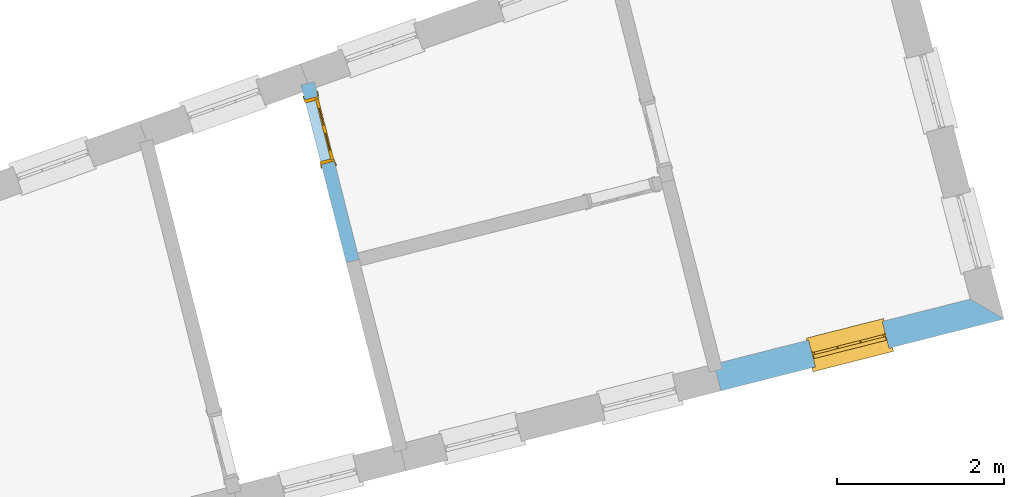
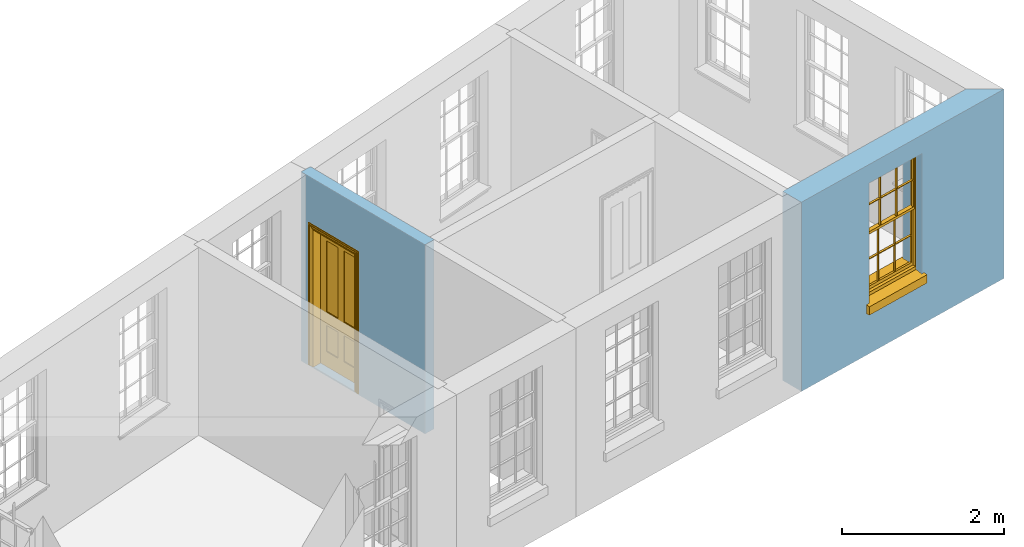
# One storey, part 6 of 11: 1 door, 1 window, 2 openings, plus 2 elements that do not belong to this part.
"""IFC2X3 building model written with IfcOpenShell, lengths in metres."""

from ifc_helpers import new_model, si_unit, frame, origin, place, context, subcontext, project, spatial, polyline, outline, extrude, faceted_brep, material, layer, layer_set, layer_usage, element, fill, save


model = new_model("IFC2X3")

# Units and contexts
model_context = context("Model", 3, world=origin())
body_context = subcontext(model_context, "Body", "Model", "MODEL_VIEW")
ifc_project = project(units=[si_unit("PLANEANGLEUNIT", "RADIAN"), si_unit("MASSUNIT", "GRAM", prefix="KILO"), si_unit("FORCEUNIT", "NEWTON", prefix="KILO"), si_unit("LENGTHUNIT", "METRE")], contexts=[model_context])

# Site, building, storey
site_placement = place(None, origin())
site = spatial("IfcSite", under=ifc_project, at=site_placement, CompositionType="ELEMENT")
building_placement = place(None, origin())
building = spatial("IfcBuilding", under=site, at=building_placement, Name="Building plot-13", CompositionType="ELEMENT")
storey_placement = place(None, frame((0.0, 0.0, 6.7)))
storey = spatial("IfcBuildingStorey", under=building, at=storey_placement, Name="Floor 1", CompositionType="ELEMENT", Elevation=6.7)

# Wall, opening, window
ifc_material_1 = material(Name="Masonry")
ifc_layer_1 = layer(ifc_material_1, 0.33, ventilated=False)
ifc_layer_set_1 = layer_set([ifc_layer_1], Name="My Wall")
ifc_layer_usage_1 = layer_usage(ifc_layer_set_1, "AXIS2", "NEGATIVE", 0.08)
wall_1_placement = place(storey_placement, origin())
wall_1 = element("IfcWallStandardCase", 1, at=wall_1_placement, inside=storey, material=ifc_layer_usage_1, Name="exterior", context=body_context, shape_type="SweptSolid", body=[
    extrude(outline(polyline([(76.9221166060511, 46.4727132498904), (77.0032448604169, 46.1528410780099), (80.3857854678444, 47.0107450750622), (79.9817754258731, 47.2487256724398), (76.9221166060511, 46.4727132498904)])), origin(), (0.0, 0.0, 1.0), 2.85),
])
opening_1_placement = place(storey_placement, frame((0.0, 0.0, 0.75)))
opening_1 = element("IfcOpeningElement", 2, at=opening_1_placement, cuts=wall_1, Name="Opening", ObjectType="Opening", context=body_context, shape_type="SweptSolid", body=[
    extrude(outline(polyline([(78.1311755833539, 46.4389148869927), (79.0132473300547, 46.6626321944863), (78.9321190756889, 46.9825043663668), (78.0500473289881, 46.7587870588732), (78.1311755833539, 46.4389148869927)])), origin(), (0.0, 0.0, 1.0), 1.82),
])
window_placement = place(storey_placement, frame((78.069714784592, 46.6812422899325, 0.75), z_axis=(0.0, 0.0, 1.0), x_axis=(0.882071746700802, 0.223717307493615, 0.0)))
window = element("IfcWindow", 3, at=window_placement, inside=storey, Name="bedroom outside window", OverallHeight=1.82, OverallWidth=0.91, context=body_context, shape_type="Brep", held_by="IfcProductRepresentation", body=[
    faceted_brep([(0.033125, -0.105, 0.975209), (0.01, -0.105, 0.975209), (0.033125, -0.105, 1.376042), (0.876875, -0.105, 0.975209), (0.876875, -0.105, 1.376042), (0.9, -0.105, 0.975209), (0.876875, -0.105, 1.386042), (0.876875, -0.105, 1.786875), (0.9, -0.105, 1.81), (0.033125, -0.105, 1.786875), (0.033125, -0.105, 1.386042), (0.01, -0.105, 1.81), (0.876875, -0.135, 1.376042), (0.876875, -0.135, 0.975209), (0.9, -0.135, 0.937083), (0.033125, -0.135, 1.786875), (0.01, -0.135, 1.81), (0.033125, -0.135, 1.386042), (0.01, -0.135, 0.937083), (0.033125, -0.135, 0.975209), (0.033125, -0.135, 1.376042), (0.876875, -0.135, 1.786875), (0.876875, -0.135, 1.386042), (0.9, -0.135, 1.81), (0.033125, -0.105, 0.937083), (0.01, -0.105, 0.937083), (0.033125, -0.105, 0.53625), (0.876875, -0.105, 0.937083), (0.876875, -0.105, 0.53625), (0.9, -0.105, 0.937083), (0.876875, -0.105, 0.52625), (0.876875, -0.105, 0.125417), (0.9, -0.105, 0.077167), (0.033125, -0.105, 0.125417), (0.033125, -0.105, 0.52625), (0.01, -0.105, 0.077167), (-0.0425, -0.25, 0.01), (-0.0425, -0.3, 0.001667), (0.0, -0.25, 0.01), (0.9525, -0.25, 0.01), (0.91, -0.25, 0.01), (0.9525, -0.3, 0.001667), (-0.02, 0.08, 0.077167), (0.0, 0.08, 0.077167), (-0.02, 0.11, 0.077167), (0.0, -0.06, 0.077167), (0.01, -0.06, 0.077167), (0.91, -0.06, 0.077167), (0.91, 0.08, 0.077167), (0.9, -0.06, 0.077167), (0.93, 0.08, 0.077167), (0.93, 0.11, 0.077167), (0.01, -0.075, 0.975209), (0.9, -0.075, 0.975209), (0.876875, -0.075, 0.125417), (0.876875, -0.075, 0.52625), (0.9, -0.075, 0.077167), (0.876875, -0.075, 0.53625), (0.876875, -0.075, 0.937083), (0.033125, -0.075, 0.125417), (0.01, -0.075, 0.077167), (0.033125, -0.075, 0.52625), (0.033125, -0.075, 0.937083), (0.033125, -0.075, 0.53625), (-0.02, 0.08, 0.052167), (-0.02, 0.11, 0.052167), (0.93, 0.11, 0.052167), (0.93, 0.08, 0.052167), (0.91, 0.08, 0.052167), (0.0, 0.08, 0.052167), (0.91, -0.15, 0.026667), (0.0, -0.15, 0.026667), (-0.0425, -0.3, -0.123333), (0.9525, -0.3, -0.123333), (-0.0425, -0.25, -0.123333), (0.9525, -0.25, -0.123333), (0.01, -0.06, 1.81), (0.9, -0.06, 1.81), (0.0, -0.06, 1.82), (0.91, -0.06, 1.82), (0.01, -0.15, 0.077167), (0.9, -0.15, 0.077167), (0.592292, -0.105, 0.125417), (0.592292, -0.075, 0.125417), (0.317708, -0.075, 0.125417), (0.317708, -0.105, 0.125417), (0.592292, -0.105, 0.53625), (0.317708, -0.105, 0.53625), (0.317708, -0.105, 0.52625), (0.592292, -0.105, 0.52625), (0.592292, -0.075, 0.53625), (0.317708, -0.075, 0.53625), (0.592292, -0.135, 1.386042), (0.592292, -0.105, 1.386042), (0.317708, -0.105, 1.386042), (0.317708, -0.135, 1.386042), (0.317708, -0.135, 1.376042), (0.592292, -0.135, 1.376042), (0.317708, -0.105, 1.376042), (0.592292, -0.105, 1.376042), (0.602292, -0.135, 1.376042), (0.592292, -0.135, 0.975209), (0.602292, -0.135, 0.975209), (0.602292, -0.105, 0.975209), (0.592292, -0.105, 0.975209), (0.602292, -0.105, 1.376042), (0.602292, -0.075, 0.53625), (0.602292, -0.105, 0.53625), (0.317708, -0.075, 0.52625), (0.307708, -0.075, 0.125417), (0.307708, -0.075, 0.52625), (0.602292, -0.075, 0.52625), (0.602292, -0.075, 0.125417), (0.592292, -0.075, 0.52625), (0.307708, -0.075, 0.53625), (0.317708, -0.075, 0.937083), (0.307708, -0.075, 0.937083), (0.602292, -0.075, 0.937083), (0.592292, -0.075, 0.937083), (0.307708, -0.105, 0.52625), (0.307708, -0.105, 0.125417), (0.307708, -0.105, 0.53625), (0.307708, -0.105, 0.937083), (0.592292, -0.105, 0.937083), (0.317708, -0.105, 0.937083), (0.602292, -0.105, 0.937083), (0.602292, -0.105, 0.52625), (0.602292, -0.105, 0.125417), (0.307708, -0.135, 1.386042), (0.307708, -0.135, 1.376042), (0.307708, -0.135, 0.975209), (0.317708, -0.135, 0.975209), (0.317708, -0.135, 1.786875), (0.307708, -0.135, 1.786875), (0.602292, -0.135, 1.786875), (0.592292, -0.135, 1.786875), (0.602292, -0.135, 1.386042), (0.602292, -0.105, 1.386042), (0.307708, -0.105, 1.386042), (0.307708, -0.105, 1.786875), (0.317708, -0.105, 1.786875), (0.592292, -0.105, 1.786875), (0.602292, -0.105, 1.786875), (0.307708, -0.105, 1.376042), (0.317708, -0.105, 0.975209), (0.307708, -0.105, 0.975209), (0.91, -0.15, 1.82), (0.9, -0.15, 1.81), (0.01, -0.15, 1.81), (0.0, -0.15, 1.82), (0.91, -0.25, 0.0), (0.0, -0.25, 0.0), (0.91, 0.08, 0.0), (0.0, 0.08, 0.0)], [[[0, 1, 2]], [[3, 4, 5]], [[6, 7, 8]], [[9, 10, 11]], [[12, 13, 14]], [[15, 16, 17]], [[18, 19, 20]], [[21, 22, 23]], [[24, 25, 26]], [[27, 28, 29]], [[30, 31, 32]], [[33, 34, 35]], [[14, 27, 29]], [[25, 24, 18]], [[36, 37, 38]], [[39, 40, 41]], [[42, 43, 44]], [[45, 46, 43]], [[47, 48, 49]], [[50, 51, 48]], [[1, 0, 52]], [[5, 53, 3]], [[54, 55, 56]], [[57, 58, 53]], [[59, 60, 61]], [[62, 63, 52]], [[48, 43, 46, 49]], [[51, 44, 43, 48]], [[64, 42, 44, 65]], [[65, 44, 51, 66]], [[66, 51, 50, 67]], [[65, 66, 68, 69]], [[60, 56, 49, 46]], [[70, 71, 38, 40]], [[37, 41, 40, 38]], [[37, 72, 73, 41]], [[74, 75, 73, 72]], [[8, 11, 76, 77]], [[76, 78, 79, 77]], [[32, 35, 80, 81]], [[81, 80, 71, 70]], [[82, 83, 84, 85]], [[86, 87, 88, 89]], [[86, 90, 91, 87]], [[92, 93, 94, 95]], [[92, 95, 96, 97]], [[96, 98, 99, 97]], [[100, 97, 101, 102]], [[103, 104, 99, 105]], [[97, 99, 104, 101]], [[102, 103, 105, 100]], [[28, 57, 106, 107]], [[108, 84, 109, 110]], [[111, 112, 83, 113]], [[114, 110, 61, 63]], [[90, 113, 108, 91]], [[115, 91, 114, 116]], [[117, 106, 90, 118]], [[111, 106, 57, 55]], [[119, 110, 109, 120]], [[34, 61, 110, 119]], [[89, 113, 83, 82]], [[88, 108, 113, 89]], [[85, 84, 108, 88]], [[121, 114, 63, 26]], [[122, 116, 114, 121]], [[123, 118, 90, 86]], [[87, 91, 115, 124]], [[107, 106, 117, 125]], [[126, 111, 55, 30]], [[127, 112, 111, 126]], [[126, 30, 28, 107]], [[88, 119, 120, 85]], [[126, 89, 82, 127]], [[125, 123, 86, 107]], [[121, 26, 34, 119]], [[124, 122, 121, 87]], [[128, 17, 20, 129]], [[96, 129, 130, 131]], [[132, 133, 128, 95]], [[134, 135, 92, 136]], [[100, 12, 22, 136]], [[137, 6, 4, 105]], [[94, 138, 139, 140]], [[137, 93, 141, 142]], [[99, 98, 94, 93]], [[143, 2, 10, 138]], [[144, 145, 143, 98]], [[129, 143, 145, 130]], [[20, 2, 143, 129]], [[131, 144, 98, 96]], [[128, 138, 10, 17]], [[133, 139, 138, 128]], [[135, 141, 93, 92]], [[95, 94, 140, 132]], [[22, 6, 137, 136]], [[136, 137, 142, 134]], [[100, 105, 4, 12]], [[107, 86, 89, 126]], [[106, 111, 113, 90]], [[91, 108, 110, 114]], [[87, 121, 119, 88]], [[97, 100, 136, 92]], [[129, 96, 95, 128]], [[98, 143, 138, 94]], [[105, 99, 93, 137]], [[131, 101, 104, 144]], [[124, 115, 118, 123]], [[132, 140, 141, 135]], [[120, 109, 59, 33]], [[15, 9, 139, 133]], [[134, 142, 7, 21]], [[31, 54, 112, 127]], [[36, 74, 72, 37]], [[39, 41, 73, 75]], [[18, 14, 101, 131]], [[23, 16, 132, 135]], [[83, 56, 60, 84]], [[52, 53, 118, 115]], [[53, 52, 144, 104]], [[11, 8, 141, 140]], [[14, 18, 124, 123]], [[2, 1, 11, 10]], [[8, 5, 4, 6]], [[57, 53, 56, 55]], [[60, 52, 63, 61]], [[26, 25, 35, 34]], [[32, 29, 28, 30]], [[14, 23, 22, 12]], [[18, 20, 17, 16]], [[19, 0, 2, 20]], [[17, 10, 9, 15]], [[12, 4, 3, 13]], [[21, 7, 6, 22]], [[27, 58, 57, 28]], [[30, 55, 54, 31]], [[33, 59, 61, 34]], [[26, 63, 62, 24]], [[5, 8, 77, 53]], [[76, 11, 1, 52]], [[46, 45, 78, 76]], [[49, 77, 79, 47]], [[70, 146, 147, 81]], [[71, 80, 148, 149]], [[19, 130, 145, 0]], [[102, 13, 3, 103]], [[116, 122, 24, 62]], [[29, 32, 81, 14]], [[80, 35, 25, 18]], [[60, 46, 76, 52]], [[77, 49, 56, 53]], [[23, 14, 81, 147]], [[16, 148, 80, 18]], [[35, 85, 120]], [[120, 33, 35]], [[127, 82, 32]], [[32, 31, 127]], [[32, 82, 85, 35]], [[102, 101, 14]], [[14, 13, 102]], [[18, 131, 130]], [[130, 19, 18]], [[134, 21, 23]], [[23, 135, 134]], [[16, 15, 133]], [[133, 132, 16]], [[11, 140, 139]], [[139, 9, 11]], [[142, 141, 8]], [[8, 7, 142]], [[23, 147, 148, 16]], [[146, 149, 148, 147]], [[52, 115, 116]], [[116, 62, 52]], [[118, 53, 117]], [[58, 117, 53]], [[27, 125, 117, 58]], [[56, 83, 112]], [[112, 54, 56]], [[109, 84, 60]], [[60, 59, 109]], [[125, 27, 14]], [[14, 123, 125]], [[122, 124, 18]], [[18, 24, 122]], [[145, 144, 52]], [[52, 0, 145]], [[103, 3, 53]], [[53, 104, 103]], [[79, 78, 149, 146]], [[78, 45, 71, 149]], [[146, 70, 47, 79]], [[150, 75, 74, 151]], [[68, 66, 67]], [[48, 68, 67, 50]], [[69, 64, 65]], [[42, 64, 69, 43]], [[69, 68, 152, 153]], [[70, 68, 48, 47]], [[150, 152, 68, 70]], [[43, 69, 71, 45]], [[69, 153, 151, 71]], [[152, 150, 151, 153]], [[38, 151, 74, 36]], [[71, 151, 38]], [[39, 75, 150, 40]], [[40, 150, 70]]]),
])
fill(opening_1, window)

# Wall, opening, door
ifc_material_2 = material(Name="Masonry")
ifc_layer_2 = layer(ifc_material_2, 0.16, ventilated=False)
ifc_layer_set_2 = layer_set([ifc_layer_2], Name="My Wall")
ifc_layer_usage_2 = layer_usage(ifc_layer_set_2, "AXIS2", "NEGATIVE", 0.08)
wall_2_placement = place(storey_placement, origin())
wall_2 = element("IfcWallStandardCase", 4, at=wall_2_placement, inside=storey, material=ifc_layer_usage_2, Name="interior", context=body_context, shape_type="SweptSolid", body=[
    extrude(outline(polyline([(72.1409472860622, 49.8463171225142), (71.9858577481808, 49.8069822113066), (72.5242252597805, 47.684308839971), (72.6793147976619, 47.7236437511786), (72.1409472860622, 49.8463171225142)])), origin(), (0.0, 0.0, 1.0), 2.85),
])
opening_2_placement = place(storey_placement, frame((0.0, 0.0, 0.0199999999999996)))
opening_2 = element("IfcOpeningElement", 5, at=opening_2_placement, cuts=wall_2, Name="Opening", ObjectType="Opening", context=body_context, shape_type="SweptSolid", body=[
    extrude(outline(polyline([(72.0301095232894, 49.6325064811899), (72.2267840793278, 48.8570587917826), (72.3818736172093, 48.8963937029903), (72.1851990611709, 49.6718413923976), (72.0301095232894, 49.6325064811899)])), origin(), (0.0, 0.0, 1.0), 2.1),
])
door_placement = place(storey_placement, frame((72.1076542922301, 49.6521739367938, 0.0199999999999996), z_axis=(0.0, 0.0, 1.0), x_axis=(0.196674556038388, -0.775447689407287, 0.0)))
door = element("IfcDoor", 6, at=door_placement, inside=storey, Name="circulation inside door", OverallHeight=2.1, OverallWidth=0.8, context=body_context, shape_type="Brep", held_by="IfcProductRepresentation", body=[
    faceted_brep([(0.773, 0.08, 1.895), (0.66, 0.08, 1.895), (0.66, 0.08, 2.073), (0.773, 0.08, 2.073), (0.773, 0.08, 0.82), (0.66, 0.08, 0.82), (0.45, 0.08, 1.895), (0.45, 0.08, 2.073), (0.773, 0.08, 0.62), (0.66, 0.08, 0.62), (0.66, 0.065, 0.82), (0.66, 0.065, 1.895), (0.45, 0.065, 1.895), (0.35, 0.08, 1.895), (0.35, 0.08, 2.073), (0.773, 0.08, 0.225), (0.66, 0.08, 0.225), (0.45, 0.08, 0.62), (0.45, 0.08, 0.82), (0.45, 0.065, 0.82), (0.35, 0.08, 0.82), (0.14, 0.08, 2.073), (0.14, 0.08, 1.895), (0.773, 0.08, 0.0), (0.66, 0.08, 0.0), (0.66, 0.065, 0.225), (0.66, 0.065, 0.62), (0.45, 0.065, 0.62), (0.35, 0.08, 0.62), (0.35, 0.065, 0.82), (0.35, 0.065, 1.895), (0.14, 0.065, 1.895), (0.027, 0.08, 2.073), (0.027, 0.08, 1.895), (0.773, 0.042, 0.0), (0.66, 0.042, 0.0), (0.45, 0.08, 0.0), (0.45, 0.08, 0.225), (0.45, 0.065, 0.225), (0.35, 0.08, 0.225), (0.14, 0.08, 0.82), (0.14, 0.08, 0.62), (0.14, 0.065, 0.82), (0.027, 0.08, 0.82), (0.773, 0.042, 0.225), (0.66, 0.042, 0.225), (0.45, 0.042, 0.0), (0.35, 0.08, 0.0), (0.35, 0.065, 0.225), (0.35, 0.065, 0.62), (0.14, 0.065, 0.62), (0.027, 0.08, 0.62), (0.773, 0.042, 0.62), (0.66, 0.042, 0.62), (0.45, 0.042, 0.225), (0.35, 0.042, 0.0), (0.14, 0.08, 0.225), (0.14, 0.08, 0.0), (0.14, 0.065, 0.225), (0.027, 0.08, 0.225), (0.773, 0.042, 0.82), (0.66, 0.042, 0.82), (0.66, 0.057, 0.62), (0.66, 0.057, 0.225), (0.45, 0.057, 0.225), (0.35, 0.042, 0.225), (0.14, 0.042, 0.0), (0.027, 0.08, 0.0), (0.773, 0.042, 1.895), (0.66, 0.042, 1.895), (0.45, 0.042, 0.62), (0.45, 0.042, 0.82), (0.45, 0.057, 0.62), (0.35, 0.042, 0.62), (0.14, 0.042, 0.225), (0.027, 0.042, 0.0), (0.773, 0.042, 2.073), (0.66, 0.042, 2.073), (0.66, 0.057, 1.895), (0.66, 0.057, 0.82), (0.45, 0.057, 0.82), (0.35, 0.042, 0.82), (0.35, 0.057, 0.62), (0.35, 0.057, 0.225), (0.14, 0.057, 0.225), (0.027, 0.042, 0.225), (0.45, 0.042, 1.895), (0.45, 0.042, 2.073), (0.45, 0.057, 1.895), (0.35, 0.042, 1.895), (0.14, 0.042, 0.82), (0.14, 0.042, 0.62), (0.14, 0.057, 0.62), (0.027, 0.042, 0.62), (0.35, 0.042, 2.073), (0.35, 0.057, 1.895), (0.35, 0.057, 0.82), (0.14, 0.057, 0.82), (0.027, 0.042, 0.82), (0.14, 0.042, 2.073), (0.14, 0.042, 1.895), (0.14, 0.057, 1.895), (0.027, 0.042, 1.895), (0.027, 0.042, 2.073), (0.02, 0.085, 0.0), (0.005, 0.09, 0.0), (0.005, 0.09, 2.095), (0.02, 0.085, 2.08), (0.02, 0.08, 0.0), (0.0, 0.085, 0.0), (0.0, 0.085, 2.1), (0.795, 0.09, 2.095), (0.78, 0.085, 2.08), (0.02, 0.08, 2.08), (0.0, 0.08, 0.0), (-0.032, 0.095, 0.0), (-0.032, 0.095, 2.132), (0.8, 0.085, 2.1), (0.795, 0.09, 0.0), (0.78, 0.085, 0.0), (0.78, 0.08, 2.08), (0.04, 0.04, 0.0), (0.025, 0.04, 0.0), (0.025, 0.04, 2.075), (0.04, 0.04, 2.06), (-0.04, 0.09, 0.0), (-0.04, 0.09, 2.14), (0.832, 0.095, 2.132), (0.8, 0.085, 0.0), (0.78, 0.08, 0.0), (0.8, 0.08, 0.0), (0.86, 0.08, 0.0), (0.86, 0.08, 2.16), (0.8, 0.08, 2.1), (-0.06, 0.08, 2.16), (0.0, 0.08, 2.1), (-0.06, 0.08, 0.0), (-0.04, 0.095, 0.0), (-0.04, 0.095, 2.14), (0.84, 0.09, 2.14), (0.832, 0.095, 0.0), (0.84, 0.09, 0.0), (0.86, 0.095, 0.0), (0.86, 0.095, 2.16), (-0.06, 0.095, 2.16), (-0.06, 0.095, 0.0), (0.84, 0.095, 0.0), (0.84, 0.095, 2.14), (-0.025, -0.095, 0.0), (-0.025, -0.09, 0.0), (-0.025, -0.09, 2.125), (-0.025, -0.095, 2.125), (-0.017, -0.095, 0.0), (-0.017, -0.095, 2.117), (0.825, -0.09, 2.125), (0.825, -0.095, 2.125), (0.825, -0.095, 0.0), (0.845, -0.095, 0.0), (-0.045, -0.095, 2.145), (-0.045, -0.095, 0.0), (0.845, -0.095, 2.145), (0.015, -0.085, 0.0), (0.015, -0.085, 2.085), (0.817, -0.095, 2.117), (0.825, -0.09, 0.0), (0.845, -0.08, 0.0), (0.845, -0.08, 2.145), (-0.045, -0.08, 2.145), (-0.045, -0.08, 0.0), (0.02, -0.09, 0.0), (0.02, -0.09, 2.08), (0.785, -0.085, 2.085), (0.817, -0.095, 0.0), (0.8, -0.08, 0.0), (0.8, -0.08, 2.1), (0.0, -0.08, 2.1), (0.0, -0.08, 0.0), (0.035, -0.085, 0.0), (0.035, -0.085, 2.065), (0.78, -0.09, 2.08), (0.785, -0.085, 0.0), (0.775, 0.04, 2.075), (0.76, 0.04, 2.06), (0.035, -0.08, 2.065), (0.035, -0.08, 0.0), (0.765, -0.085, 2.065), (0.78, -0.09, 0.0), (0.765, -0.08, 0.0), (0.765, -0.08, 2.065), (0.765, -0.085, 0.0), (0.04, -0.08, 2.06), (0.04, -0.08, 0.0), (0.76, -0.08, 2.06), (0.76, -0.08, 0.0), (0.76, 0.04, 0.0), (0.775, 0.04, 0.0), (0.025, 0.08, 0.0), (0.025, 0.08, 2.075), (0.775, 0.08, 0.0), (0.775, 0.08, 2.075)], [[[0, 1, 2, 3]], [[1, 0, 4, 5]], [[1, 6, 7, 2]], [[8, 9, 5, 4]], [[1, 5, 10, 11]], [[6, 1, 11, 12]], [[6, 13, 14, 7]], [[15, 16, 9, 8]], [[9, 17, 18, 5]], [[5, 18, 19, 10]], [[10, 19, 12, 11]], [[18, 6, 12, 19]], [[18, 20, 13, 6]], [[21, 14, 13, 22]], [[23, 24, 16, 15]], [[9, 16, 25, 26]], [[17, 9, 26, 27]], [[17, 28, 20, 18]], [[13, 20, 29, 30]], [[22, 13, 30, 31]], [[32, 21, 22, 33]], [[34, 35, 24, 23]], [[24, 36, 37, 16]], [[16, 37, 38, 25]], [[25, 38, 27, 26]], [[37, 17, 27, 38]], [[37, 39, 28, 17]], [[40, 20, 28, 41]], [[20, 40, 42, 29]], [[31, 30, 29, 42]], [[40, 22, 31, 42]], [[33, 22, 40, 43]], [[35, 34, 44, 45]], [[35, 46, 36, 24]], [[36, 47, 39, 37]], [[28, 39, 48, 49]], [[41, 28, 49, 50]], [[43, 40, 41, 51]], [[45, 44, 52, 53]], [[46, 35, 45, 54]], [[46, 55, 47, 36]], [[56, 39, 47, 57]], [[39, 56, 58, 48]], [[50, 49, 48, 58]], [[56, 41, 50, 58]], [[51, 41, 56, 59]], [[53, 52, 60, 61]], [[45, 53, 62, 63]], [[54, 45, 63, 64]], [[55, 46, 54, 65]], [[55, 66, 57, 47]], [[59, 56, 57, 67]], [[61, 60, 68, 69]], [[70, 53, 61, 71]], [[53, 70, 72, 62]], [[72, 64, 63, 62]], [[70, 54, 64, 72]], [[65, 54, 70, 73]], [[65, 74, 66, 55]], [[67, 57, 66, 75]], [[69, 68, 76, 77]], [[61, 69, 78, 79]], [[71, 61, 79, 80]], [[73, 70, 71, 81]], [[65, 73, 82, 83]], [[74, 65, 83, 84]], [[74, 85, 75, 66]], [[86, 69, 77, 87]], [[69, 86, 88, 78]], [[88, 80, 79, 78]], [[86, 71, 80, 88]], [[81, 71, 86, 89]], [[73, 81, 90, 91]], [[73, 91, 92, 82]], [[83, 82, 92, 84]], [[91, 74, 84, 92]], [[91, 93, 85, 74]], [[89, 86, 87, 94]], [[81, 89, 95, 96]], [[90, 81, 96, 97]], [[90, 98, 93, 91]], [[94, 99, 100, 89]], [[89, 100, 101, 95]], [[101, 97, 96, 95]], [[100, 90, 97, 101]], [[100, 102, 98, 90]], [[99, 103, 102, 100]], [[32, 103, 99, 21]], [[102, 103, 32, 33]], [[98, 102, 33, 43]], [[21, 99, 94, 14]], [[94, 87, 7, 14]], [[7, 87, 77, 2]], [[76, 3, 2, 77]], [[43, 51, 93, 98]], [[51, 59, 85, 93]], [[67, 75, 85, 59]], [[34, 23, 15, 44]], [[44, 15, 8, 52]], [[52, 8, 4, 60]], [[0, 68, 60, 4]], [[0, 3, 76, 68]], [[104, 105, 106, 107]], [[104, 108, 109, 105]], [[105, 109, 110, 106]], [[107, 106, 111, 112]], [[107, 113, 108, 104]], [[114, 109, 108]], [[109, 115, 116, 110]], [[106, 110, 117, 111]], [[112, 111, 118, 119]], [[113, 107, 112, 120]], [[121, 122, 123, 124]], [[115, 109, 114, 125]], [[115, 125, 126, 116]], [[110, 116, 127, 117]], [[111, 117, 128, 118]], [[118, 128, 129, 119]], [[120, 112, 119, 129]], [[130, 129, 128]], [[130, 131, 132, 133]], [[133, 132, 134, 135]], [[135, 134, 136, 114]], [[136, 125, 114]], [[125, 137, 138, 126]], [[116, 126, 139, 127]], [[117, 127, 140, 128]], [[141, 130, 128, 140]], [[131, 130, 141]], [[131, 142, 143, 132]], [[132, 143, 144, 134]], [[134, 144, 145, 136]], [[137, 125, 136, 145]], [[143, 142, 146]], [[143, 146, 147]], [[137, 145, 144]], [[143, 147, 138]], [[138, 137, 144]], [[143, 138, 144]], [[126, 138, 147, 139]], [[127, 139, 141, 140]], [[142, 131, 141, 146]], [[139, 147, 146, 141]], [[148, 149, 150, 151]], [[149, 152, 153, 150]], [[151, 150, 154, 155]], [[155, 156, 157]], [[158, 159, 148]], [[158, 148, 151]], [[155, 157, 160]], [[158, 151, 155]], [[155, 160, 158]], [[152, 161, 162, 153]], [[150, 153, 163, 154]], [[155, 154, 164, 156]], [[156, 164, 165, 157]], [[157, 165, 166, 160]], [[160, 166, 167, 158]], [[158, 167, 168, 159]], [[161, 169, 170, 162]], [[153, 162, 171, 163]], [[154, 163, 172, 164]], [[165, 164, 173]], [[165, 173, 174, 166]], [[166, 174, 175, 167]], [[167, 175, 176, 168]], [[169, 177, 178, 170]], [[162, 170, 179, 171]], [[163, 171, 180, 172]], [[172, 180, 173, 164]], [[124, 123, 181, 182]], [[183, 178, 177, 184]], [[170, 178, 185, 179]], [[171, 179, 186, 180]], [[187, 173, 180]], [[185, 188, 187, 189]], [[188, 185, 178, 183]], [[179, 185, 189, 186]], [[189, 187, 180, 186]], [[190, 183, 184, 191]], [[192, 188, 183, 190]], [[191, 184, 122, 121]], [[124, 190, 191, 121]], [[193, 187, 188, 192]], [[182, 192, 190, 124]], [[184, 176, 122]], [[194, 195, 187, 193]], [[192, 182, 194, 193]], [[161, 176, 184]], [[114, 108, 122, 176]], [[173, 187, 195]], [[152, 149, 176, 161]], [[169, 161, 184, 177]], [[196, 122, 108]], [[176, 175, 135, 114]], [[173, 195, 129, 130]], [[176, 149, 168]], [[123, 122, 196, 197]], [[196, 108, 113, 197]], [[175, 174, 133, 135]], [[198, 129, 195]], [[133, 174, 173, 130]], [[159, 168, 149, 148]], [[181, 123, 197, 199]], [[197, 113, 120, 199]], [[199, 120, 129, 198]], [[195, 181, 199, 198]], [[195, 194, 182, 181]]]),
])
fill(opening_2, door)

save(model, "model.ifc")
